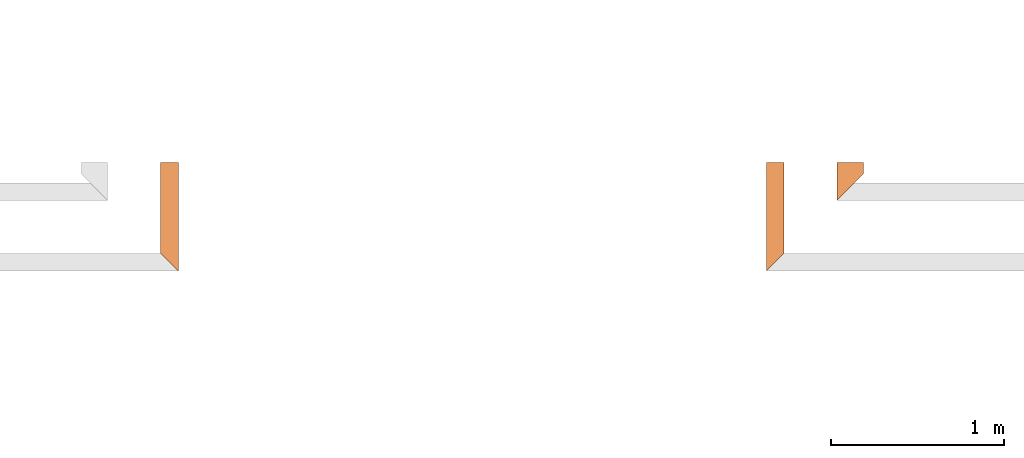
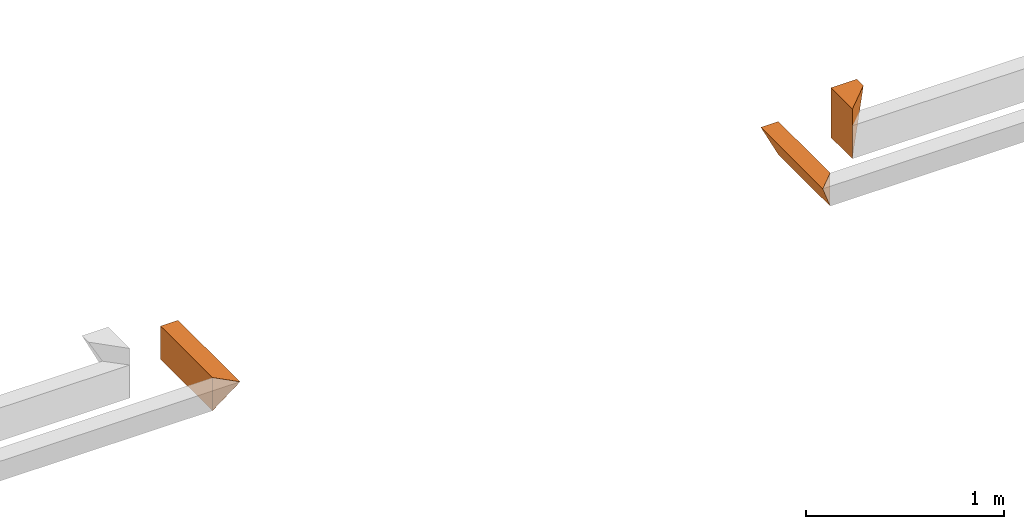
# One storey, part 8 of 8: 3 proxies.
"""IFC4 building model written with IfcOpenShell, lengths in feet."""

import ifcopenshell
import ifcopenshell.guid

model = None  # the IFC model being written
_history = None  # IfcOwnerHistory: only IFC2X3 demands one
_inside = {}  # id of a spatial element -> (the spatial element, [elements in it])
_under = {}  # id of a project, library or spatial element -> (it, [spatial elements below it])
_declared = {}  # id of a project -> (the project, [libraries it declares])
_typed = {}  # id of a type object -> (the type object, [elements of that type])
_made_of = {}  # id of a material, layer set ... -> (it, [elements and type objects made of it])


def new_model(schema):
    """Start an empty IFC model of exactly this schema.

    Asked for "IFC4X3", IfcOpenShell would pick the latest addendum, in which some entities
    have other attributes; the version numbers below select the first issue.
    IFC2X3 requires an IfcOwnerHistory on every rooted entity: one is made here for all.
    """
    global model, _history
    if schema == "IFC4X3":
        model = ifcopenshell.file(schema_version=(4, 3, 0, 0))
    else:
        model = ifcopenshell.file(schema=schema)
    _inside.clear()
    _under.clear()
    _declared.clear()
    _typed.clear()
    _made_of.clear()
    _history = None
    if model.schema == "IFC2X3":
        org = make("IfcOrganization", Name="unknown")
        user = make(
            "IfcPersonAndOrganization",
            ThePerson=make("IfcPerson", FamilyName="unknown"),
            TheOrganization=org,
        )
        app = make(
            "IfcApplication",
            ApplicationDeveloper=org,
            Version="unknown",
            ApplicationFullName="unknown",
            ApplicationIdentifier="unknown",
        )
        _history = make(
            "IfcOwnerHistory",
            OwningUser=user,
            OwningApplication=app,
            ChangeAction="ADDED",
            CreationDate=0,
        )
    return model


def make(cls, **values):
    """One entity of the class cls with the attributes given. An attribute that is None is left unset."""
    return model.create_entity(
        cls, **{name: value for name, value in values.items() if value is not None}
    )


def entity(cls, *values):
    """Any entity or typed value of the class cls, its attributes in the order of the schema. None: left unset."""
    e = model.create_entity(cls)
    for i, value in enumerate(values):
        if value is not None:
            e[i] = value
    return e


def rooted(cls, **values):
    """An entity with a GlobalId (a new one), such as an element, a storey or a relation."""
    return make(cls, GlobalId=ifcopenshell.guid.new(), OwnerHistory=_history, **values)


def si_unit(unit_type, name, prefix=None):
    """IfcSIUnit, for example si_unit("LENGTHUNIT", "METRE", prefix="MILLI")."""
    return make("IfcSIUnit", UnitType=unit_type, Prefix=prefix, Name=name)


def converted_unit(unit_type, name, factor, base, dimensions=None, offset=None):
    """IfcConversionBasedUnit, such as the inch: factor (a typed value) times the base unit."""
    return make(
        "IfcConversionBasedUnit"
        if offset is None
        else "IfcConversionBasedUnitWithOffset",
        ConversionOffset=offset,
        Dimensions=None
        if dimensions is None
        else entity("IfcDimensionalExponents", *dimensions),
        UnitType=unit_type,
        Name=name,
        ConversionFactor=make(
            "IfcMeasureWithUnit", ValueComponent=factor, UnitComponent=base
        ),
    )


def derived_unit(unit_type, elements):
    """IfcDerivedUnit: a product of units, each with its exponent."""
    return make(
        "IfcDerivedUnit",
        Elements=[
            make("IfcDerivedUnitElement", Unit=unit, Exponent=power)
            for unit, power in elements
        ],
        UnitType=unit_type,
    )


def assignment(units):
    """IfcUnitAssignment: the units of a project."""
    return None if units is None else make("IfcUnitAssignment", Units=units)


def point(xyz):
    """IfcCartesianPoint."""
    return None if xyz is None else make("IfcCartesianPoint", Coordinates=xyz)


def direction(xyz):
    """IfcDirection."""
    return None if xyz is None else make("IfcDirection", DirectionRatios=xyz)


def frame(location, z_axis=None, x_axis=None):
    """IfcAxis2Placement3D, a coordinate frame: its origin and axes. An axis left out is left unset."""
    return make(
        "IfcAxis2Placement3D",
        Location=point(location),
        Axis=direction(z_axis),
        RefDirection=direction(x_axis),
    )


def origin():
    """The frame at (0, 0, 0) with its axes left unset."""
    return frame((0.0, 0.0, 0.0))


def place(relative_to, where):
    """IfcLocalPlacement: puts the frame where relative to a parent placement (None: the world)."""
    return make(
        "IfcLocalPlacement", PlacementRelTo=relative_to, RelativePlacement=where
    )


def context(
    kind, dimensions, precision=None, world=None, true_north=None, identifier=None
):
    """IfcGeometricRepresentationContext, for example the 3D "Model" context."""
    return make(
        "IfcGeometricRepresentationContext",
        ContextIdentifier=identifier,
        ContextType=kind,
        CoordinateSpaceDimension=dimensions,
        Precision=precision,
        WorldCoordinateSystem=world,
        TrueNorth=true_north,
    )


def subcontext(parent, identifier, kind, view, scale=None):
    """IfcGeometricRepresentationSubContext, for example "Body" below "Model"."""
    return make(
        "IfcGeometricRepresentationSubContext",
        ContextIdentifier=identifier,
        ContextType=kind,
        ParentContext=parent,
        TargetScale=scale,
        TargetView=view,
    )


def project(units=None, contexts=None):
    """IfcProject with its units and contexts."""
    return rooted(
        "IfcProject",
        Name="project",
        RepresentationContexts=contexts,
        UnitsInContext=assignment(units),
    )


def spatial(cls, under=None, at=None, **own):
    """A site, building, storey or space (cls), placed at a placement, below another one or the project."""
    s = rooted(cls, ObjectPlacement=at, **own)
    if under is not None:
        _under.setdefault(under.id(), (under, []))[1].append(s)
    return s


def shape(context_of_items, identifier, shape_type, items):
    """IfcShapeRepresentation: the items that make up one representation, for example the "Body"."""
    return make(
        "IfcShapeRepresentation",
        ContextOfItems=context_of_items,
        RepresentationIdentifier=identifier,
        RepresentationType=shape_type,
        Items=items,
    )


def made_of(thing, what):
    """Note that an element or type object is made of a material, layer set ...; save() writes the relation."""
    if what is not None:
        _made_of.setdefault(what.id(), (what, []))[1].append(thing)
    return thing


def type_object(cls, material=None, **own):
    """A type object (cls), such as IfcWallType, which elements share."""
    return made_of(rooted(cls, **own), material)


def element(
    cls,
    number,
    at=None,
    inside=None,
    cuts=None,
    type_object=None,
    material=None,
    context=None,
    identifier="Body",
    shape_type=None,
    held_by="IfcProductDefinitionShape",
    body=None,
    shapes=None,
    **own,
):
    """One element of the class cls, such as IfcWall. Its Tag is "e" and its number.

    at: its placement. inside: the storey or other place that contains it. cuts: it is an
    opening in that element (IfcRelVoidsElement). A single representation is given by context,
    identifier, shape_type and body (its items); several are given by shapes. held_by: the class
    of the entity that holds the representations. save() writes the other relations.
    """
    e = rooted(cls, Tag="e%d" % number, ObjectPlacement=at, **own)
    if body is not None:
        shapes = [shape(context, identifier, shape_type, body)]
    if shapes is not None:
        e.Representation = make(held_by, Representations=shapes)
    if inside is not None:
        _inside.setdefault(inside.id(), (inside, []))[1].append(e)
    if cuts is not None:
        rooted(
            "IfcRelVoidsElement", RelatingBuildingElement=cuts, RelatedOpeningElement=e
        )
    if type_object is not None:
        _typed.setdefault(type_object.id(), (type_object, []))[1].append(e)
    return made_of(e, material)


def aggregate(whole, parts):
    """IfcRelAggregates: a whole, such as a stair, and the parts it consists of."""
    return rooted("IfcRelAggregates", RelatingObject=whole, RelatedObjects=parts)


def save(model, path):
    """Write the relations noted so far, then the file.

    IfcRelAggregates (storeys below a building ...), IfcRelContainedInSpatialStructure (elements
    in a storey), IfcRelDefinesByType, IfcRelAssociatesMaterial and IfcRelDeclares: one each for
    every whole, place, type object, material and project.
    """
    for whole, parts in _under.values():
        aggregate(whole, parts)
    for where, things in _inside.values():
        rooted(
            "IfcRelContainedInSpatialStructure",
            RelatedElements=things,
            RelatingStructure=where,
        )
    for kind, things in _typed.values():
        rooted("IfcRelDefinesByType", RelatedObjects=things, RelatingType=kind)
    for what, things in _made_of.values():
        rooted("IfcRelAssociatesMaterial", RelatedObjects=things, RelatingMaterial=what)
    for by, libraries in _declared.values():
        rooted("IfcRelDeclares", RelatingContext=by, RelatedDefinitions=libraries)
    model.write(path)


model = new_model("IFC4")

# Units and contexts
model_context = context("Model", 3, precision=0.0001, world=origin(), true_north=direction((6.12303176911189e-17, 1.0)))
body_context = subcontext(model_context, "Body", "Model", "MODEL_VIEW")
ifc_project = project(units=[converted_unit("LENGTHUNIT", "FOOT", entity("IfcRatioMeasure", 0.3048), si_unit("LENGTHUNIT", "METRE"), dimensions=[1, 0, 0, 0, 0, 0, 0]), converted_unit("AREAUNIT", "SQUARE FOOT", entity("IfcRatioMeasure", 0.09290304), si_unit("AREAUNIT", "SQUARE_METRE"), dimensions=[2, 0, 0, 0, 0, 0, 0]), converted_unit("VOLUMEUNIT", "CUBIC FOOT", entity("IfcRatioMeasure", 0.028316846592), si_unit("VOLUMEUNIT", "CUBIC_METRE"), dimensions=[3, 0, 0, 0, 0, 0, 0]), converted_unit("PLANEANGLEUNIT", "DEGREE", entity("IfcRatioMeasure", 0.0174532925199433), si_unit("PLANEANGLEUNIT", "RADIAN"), dimensions=[0, 0, 0, 0, 0, 0, 0]), si_unit("MASSUNIT", "GRAM", prefix="KILO"), derived_unit("MASSDENSITYUNIT", [(si_unit("MASSUNIT", "GRAM", prefix="KILO"), 1), (si_unit("LENGTHUNIT", "METRE"), -3)]), derived_unit("MOMENTOFINERTIAUNIT", [(si_unit("LENGTHUNIT", "METRE"), 4)]), si_unit("TIMEUNIT", "SECOND"), si_unit("FREQUENCYUNIT", "HERTZ"), si_unit("THERMODYNAMICTEMPERATUREUNIT", "DEGREE_CELSIUS"), derived_unit("THERMALTRANSMITTANCEUNIT", [(si_unit("MASSUNIT", "GRAM", prefix="KILO"), 1), (si_unit("THERMODYNAMICTEMPERATUREUNIT", "KELVIN"), -1), (si_unit("TIMEUNIT", "SECOND"), -3)]), derived_unit("VOLUMETRICFLOWRATEUNIT", [(si_unit("LENGTHUNIT", "METRE"), 3), (si_unit("TIMEUNIT", "SECOND"), -1)]), si_unit("ELECTRICCURRENTUNIT", "AMPERE"), si_unit("ELECTRICVOLTAGEUNIT", "VOLT"), si_unit("POWERUNIT", "WATT"), si_unit("FORCEUNIT", "NEWTON"), si_unit("ILLUMINANCEUNIT", "LUX"), si_unit("LUMINOUSFLUXUNIT", "LUMEN"), si_unit("LUMINOUSINTENSITYUNIT", "CANDELA"), derived_unit("USERDEFINED", [(si_unit("MASSUNIT", "GRAM", prefix="KILO"), -1), (si_unit("LENGTHUNIT", "METRE"), -2), (si_unit("TIMEUNIT", "SECOND"), 3), (si_unit("LUMINOUSFLUXUNIT", "LUMEN"), 1)]), derived_unit("LINEARVELOCITYUNIT", [(si_unit("LENGTHUNIT", "METRE"), 1), (si_unit("TIMEUNIT", "SECOND"), -1)]), si_unit("PRESSUREUNIT", "PASCAL"), derived_unit("USERDEFINED", [(si_unit("LENGTHUNIT", "METRE"), -2), (si_unit("MASSUNIT", "GRAM", prefix="KILO"), 1), (si_unit("TIMEUNIT", "SECOND"), -2)]), derived_unit("LINEARFORCEUNIT", [(si_unit("MASSUNIT", "GRAM", prefix="KILO"), 1), (si_unit("LENGTHUNIT", "METRE"), 1), (si_unit("TIMEUNIT", "SECOND"), -2), (si_unit("LENGTHUNIT", "METRE"), -1)]), derived_unit("PLANARFORCEUNIT", [(si_unit("MASSUNIT", "GRAM", prefix="KILO"), 1), (si_unit("LENGTHUNIT", "METRE"), 1), (si_unit("TIMEUNIT", "SECOND"), -2), (si_unit("LENGTHUNIT", "METRE"), -2)])], contexts=[model_context])

# Site, building, storey
site_placement = place(None, origin())
site = spatial("IfcSite", under=ifc_project, at=site_placement, CompositionType="ELEMENT")
building_placement = place(site_placement, origin())
building = spatial("IfcBuilding", under=site, at=building_placement, CompositionType="ELEMENT")
storey_placement = place(building_placement, frame((0.0, 0.0, -12.6666666666667)))
storey = spatial("IfcBuildingStorey", under=building, at=storey_placement, Name="BASEMENT", CompositionType="ELEMENT", Elevation=-12.6666666666667)

# Proxies
building_element_proxy_type_1 = type_object("IfcBuildingElementProxyType", PredefinedType="NOTDEFINED")
proxy_1_placement = place(storey_placement, frame((-171.238160287975, 955.897091132648, 11.5833333333333)))
cartesian_point_1 = entity("IfcCartesianPoint", [0.0, 2.04818742148973, 0.0])
vertex_point_1 = entity("IfcVertexPoint", cartesian_point_1)
cartesian_point_2 = entity("IfcCartesianPoint", [0.0, 2.04818742148973, 0.669270833333343])
vertex_point_2 = entity("IfcVertexPoint", cartesian_point_2)
ifc_direction_1 = entity("IfcDirection", [0.0, 0.0, 1.0])
edge_curve_1 = entity("IfcEdgeCurve", vertex_point_1, vertex_point_2, entity("IfcTrimmedCurve", entity("IfcLine", cartesian_point_1, entity("IfcVector", ifc_direction_1, 1.0)), [cartesian_point_1], [cartesian_point_2], True, "CARTESIAN"), True)
cartesian_point_3 = entity("IfcCartesianPoint", [0.334635416666799, 2.04818742148962, 0.669270833333343])
vertex_point_3 = entity("IfcVertexPoint", cartesian_point_3)
ifc_direction_2 = entity("IfcDirection", [1.0, 0.0, 0.0])
edge_curve_2 = entity("IfcEdgeCurve", vertex_point_2, vertex_point_3, entity("IfcTrimmedCurve", entity("IfcLine", cartesian_point_2, entity("IfcVector", ifc_direction_2, 1.0)), [cartesian_point_2], [cartesian_point_3], True, "CARTESIAN"), True)
edge_curve_3 = entity("IfcEdgeCurve", vertex_point_3, vertex_point_1, entity("IfcTrimmedCurve", entity("IfcLine", cartesian_point_3, entity("IfcVector", entity("IfcDirection", [-0.447213595499947, 0.0, -0.894427190999921]), 1.0)), [cartesian_point_3], [cartesian_point_1], True, "CARTESIAN"), True)
ifc_direction_3 = entity("IfcDirection", [0.0, 1.0, 0.0])
ifc_direction_4 = entity("IfcDirection", [0.0, 0.0, -1.0])
cartesian_point_4 = entity("IfcCartesianPoint", [0.0, 0.334635416666629, 0.0])
vertex_point_4 = entity("IfcVertexPoint", cartesian_point_4)
cartesian_point_5 = entity("IfcCartesianPoint", [0.334635416666742, 0.0, 0.669270833333343])
vertex_point_5 = entity("IfcVertexPoint", cartesian_point_5)
edge_curve_4 = entity("IfcEdgeCurve", vertex_point_4, vertex_point_5, entity("IfcTrimmedCurve", entity("IfcLine", cartesian_point_4, entity("IfcVector", entity("IfcDirection", [0.40824829046386, -0.408248290463825, 0.816496580927747]), 1.0)), [cartesian_point_4], [cartesian_point_5], True, "CARTESIAN"), True)
cartesian_point_6 = entity("IfcCartesianPoint", [0.0, 0.334635416666742, 0.669270833333343])
vertex_point_6 = entity("IfcVertexPoint", cartesian_point_6)
edge_curve_5 = entity("IfcEdgeCurve", vertex_point_5, vertex_point_6, entity("IfcTrimmedCurve", entity("IfcLine", cartesian_point_5, entity("IfcVector", entity("IfcDirection", [-0.707106781186517, 0.707106781186578, 0.0]), 1.0)), [cartesian_point_5], [cartesian_point_6], True, "CARTESIAN"), True)
edge_curve_6 = entity("IfcEdgeCurve", vertex_point_6, vertex_point_4, entity("IfcTrimmedCurve", entity("IfcLine", cartesian_point_6, entity("IfcVector", ifc_direction_4, 1.0)), [cartesian_point_6], [cartesian_point_4], True, "CARTESIAN"), True)
ifc_direction_5 = entity("IfcDirection", [0.0, -1.0, 0.0])
edge_curve_7 = entity("IfcEdgeCurve", vertex_point_1, vertex_point_4, entity("IfcTrimmedCurve", entity("IfcLine", cartesian_point_1, entity("IfcVector", ifc_direction_5, 1.0)), [cartesian_point_1], [cartesian_point_4], True, "CARTESIAN"), True)
edge_curve_8 = entity("IfcEdgeCurve", vertex_point_6, vertex_point_2, entity("IfcTrimmedCurve", entity("IfcLine", cartesian_point_6, entity("IfcVector", ifc_direction_3, 1.0)), [cartesian_point_6], [cartesian_point_2], True, "CARTESIAN"), True)
edge_curve_9 = entity("IfcEdgeCurve", vertex_point_3, vertex_point_5, entity("IfcTrimmedCurve", entity("IfcLine", cartesian_point_3, entity("IfcVector", ifc_direction_5, 1.0)), [cartesian_point_3], [cartesian_point_5], True, "CARTESIAN"), True)
element("IfcBuildingElementProxy", 1, at=proxy_1_placement, inside=storey, type_object=building_element_proxy_type_1, PredefinedType="NOTDEFINED", context=body_context, shape_type="AdvancedBrep", body=[
    entity("IfcAdvancedBrep", entity("IfcClosedShell", [entity("IfcAdvancedFace", [entity("IfcFaceOuterBound", entity("IfcEdgeLoop", [entity("IfcOrientedEdge", None, None, edge_curve_1, True), entity("IfcOrientedEdge", None, None, edge_curve_2, True), entity("IfcOrientedEdge", None, None, edge_curve_3, True)]), True)], entity("IfcPlane", entity("IfcAxis2Placement3D", entity("IfcCartesianPoint", [-1.0, 2.04818742148973, 1.0]), ifc_direction_3, ifc_direction_4)), True), entity("IfcAdvancedFace", [entity("IfcFaceOuterBound", entity("IfcEdgeLoop", [entity("IfcOrientedEdge", None, None, edge_curve_4, True), entity("IfcOrientedEdge", None, None, edge_curve_5, True), entity("IfcOrientedEdge", None, None, edge_curve_6, True)]), True)], entity("IfcPlane", entity("IfcAxis2Placement3D", entity("IfcCartesianPoint", [0.0, 0.334635416666629, 2.0]), entity("IfcDirection", [-0.707106781186562, -0.707106781186533, 0.0]), entity("IfcDirection", [-0.707106781186533, 0.707106781186562, 0.0]))), True), entity("IfcAdvancedFace", [entity("IfcFaceOuterBound", entity("IfcEdgeLoop", [entity("IfcOrientedEdge", None, None, edge_curve_7, True), entity("IfcOrientedEdge", None, None, edge_curve_6, False), entity("IfcOrientedEdge", None, None, edge_curve_8, True), entity("IfcOrientedEdge", None, None, edge_curve_1, False)]), True)], entity("IfcPlane", entity("IfcAxis2Placement3D", cartesian_point_1, entity("IfcDirection", [-1.0, 0.0, 0.0]), ifc_direction_5)), True), entity("IfcAdvancedFace", [entity("IfcFaceOuterBound", entity("IfcEdgeLoop", [entity("IfcOrientedEdge", None, None, edge_curve_7, False), entity("IfcOrientedEdge", None, None, edge_curve_3, False), entity("IfcOrientedEdge", None, None, edge_curve_9, True), entity("IfcOrientedEdge", None, None, edge_curve_4, False)]), True)], entity("IfcPlane", entity("IfcAxis2Placement3D", entity("IfcCartesianPoint", [0.500000000000142, 2.04818742148962, 1.0]), entity("IfcDirection", [0.894427190999915, 0.0, -0.447213595499961]), ifc_direction_5)), True), entity("IfcAdvancedFace", [entity("IfcFaceOuterBound", entity("IfcEdgeLoop", [entity("IfcOrientedEdge", None, None, edge_curve_2, False), entity("IfcOrientedEdge", None, None, edge_curve_8, False), entity("IfcOrientedEdge", None, None, edge_curve_5, False), entity("IfcOrientedEdge", None, None, edge_curve_9, False)]), True)], entity("IfcPlane", entity("IfcAxis2Placement3D", entity("IfcCartesianPoint", [29.5000074770008, 2.96484375000227, 0.669270833333343]), ifc_direction_1, ifc_direction_2)), True)])),
])
building_element_proxy_type_2 = type_object("IfcBuildingElementProxyType", PredefinedType="NOTDEFINED")
proxy_2_placement = place(storey_placement, frame((-158.446493847068, 957.231726549315, 11.5833333333333)))
cartesian_point_7 = entity("IfcCartesianPoint", [0.5, 0.713552004822759, 1.0])
vertex_point_7 = entity("IfcVertexPoint", cartesian_point_7)
cartesian_point_8 = entity("IfcCartesianPoint", [0.0, 0.713552004822759, 0.0])
vertex_point_8 = entity("IfcVertexPoint", cartesian_point_8)
edge_curve_10 = entity("IfcEdgeCurve", vertex_point_7, vertex_point_8, entity("IfcTrimmedCurve", entity("IfcLine", cartesian_point_7, entity("IfcVector", entity("IfcDirection", [-0.44721359549996, 0.0, -0.894427190999915]), 1.0)), [cartesian_point_7], [cartesian_point_8], True, "CARTESIAN"), True)
cartesian_point_9 = entity("IfcCartesianPoint", [0.0, 0.713552004822759, 0.669270833333341])
vertex_point_9 = entity("IfcVertexPoint", cartesian_point_9)
ifc_direction_6 = entity("IfcDirection", [0.0, 0.0, 1.0])
edge_curve_11 = entity("IfcEdgeCurve", vertex_point_8, vertex_point_9, entity("IfcTrimmedCurve", entity("IfcLine", cartesian_point_8, entity("IfcVector", ifc_direction_6, 1.0)), [cartesian_point_8], [cartesian_point_9], True, "CARTESIAN"), True)
cartesian_point_10 = entity("IfcCartesianPoint", [0.0, 0.713552004822759, 1.0])
vertex_point_10 = entity("IfcVertexPoint", cartesian_point_10)
edge_curve_12 = entity("IfcEdgeCurve", vertex_point_9, vertex_point_10, entity("IfcTrimmedCurve", entity("IfcLine", cartesian_point_9, entity("IfcVector", ifc_direction_6, 1.0)), [cartesian_point_9], [cartesian_point_10], True, "CARTESIAN"), True)
edge_curve_13 = entity("IfcEdgeCurve", vertex_point_10, vertex_point_7, entity("IfcTrimmedCurve", entity("IfcLine", cartesian_point_10, entity("IfcVector", entity("IfcDirection", [1.0, 0.0, 0.0]), 1.0)), [cartesian_point_10], [cartesian_point_7], True, "CARTESIAN"), True)
ifc_direction_7 = entity("IfcDirection", [0.0, 1.0, 0.0])
ifc_direction_8 = entity("IfcDirection", [0.0, 0.0, -1.0])
cartesian_point_11 = entity("IfcCartesianPoint", [0.0, 0.0, 0.0])
vertex_point_11 = entity("IfcVertexPoint", cartesian_point_11)
cartesian_point_12 = entity("IfcCartesianPoint", [0.500000000000028, 0.499999999999886, 1.0])
vertex_point_12 = entity("IfcVertexPoint", cartesian_point_12)
edge_curve_14 = entity("IfcEdgeCurve", vertex_point_11, vertex_point_12, entity("IfcTrimmedCurve", entity("IfcLine", cartesian_point_11, entity("IfcVector", entity("IfcDirection", [0.408248290463864, 0.408248290463864, 0.816496580927725]), 1.0)), [cartesian_point_11], [cartesian_point_12], True, "CARTESIAN"), True)
cartesian_point_13 = entity("IfcCartesianPoint", [0.0, 0.0, 1.0])
vertex_point_13 = entity("IfcVertexPoint", cartesian_point_13)
edge_curve_15 = entity("IfcEdgeCurve", vertex_point_12, vertex_point_13, entity("IfcTrimmedCurve", entity("IfcLine", cartesian_point_12, entity("IfcVector", entity("IfcDirection", [-0.707106781186547, -0.707106781186547, 0.0]), 1.0)), [cartesian_point_12], [cartesian_point_13], True, "CARTESIAN"), True)
cartesian_point_14 = entity("IfcCartesianPoint", [0.0, 0.0, 0.669270833333341])
vertex_point_14 = entity("IfcVertexPoint", cartesian_point_14)
edge_curve_16 = entity("IfcEdgeCurve", vertex_point_13, vertex_point_14, entity("IfcTrimmedCurve", entity("IfcLine", cartesian_point_13, entity("IfcVector", ifc_direction_8, 1.0)), [cartesian_point_13], [cartesian_point_14], True, "CARTESIAN"), True)
edge_curve_17 = entity("IfcEdgeCurve", vertex_point_14, vertex_point_11, entity("IfcTrimmedCurve", entity("IfcLine", cartesian_point_14, entity("IfcVector", ifc_direction_8, 1.0)), [cartesian_point_14], [cartesian_point_11], True, "CARTESIAN"), True)
ifc_direction_9 = entity("IfcDirection", [0.0, -1.0, 0.0])
edge_curve_18 = entity("IfcEdgeCurve", vertex_point_7, vertex_point_12, entity("IfcTrimmedCurve", entity("IfcLine", cartesian_point_7, entity("IfcVector", ifc_direction_9, 1.0)), [cartesian_point_7], [cartesian_point_12], True, "CARTESIAN"), True)
edge_curve_19 = entity("IfcEdgeCurve", vertex_point_11, vertex_point_8, entity("IfcTrimmedCurve", entity("IfcLine", cartesian_point_8, entity("IfcVector", ifc_direction_7, 1.0)), [cartesian_point_11], [cartesian_point_8], True, "CARTESIAN"), True)
edge_curve_20 = entity("IfcEdgeCurve", vertex_point_10, vertex_point_13, entity("IfcTrimmedCurve", entity("IfcLine", cartesian_point_10, entity("IfcVector", ifc_direction_9, 1.0)), [cartesian_point_10], [cartesian_point_13], True, "CARTESIAN"), True)
element("IfcBuildingElementProxy", 2, at=proxy_2_placement, inside=storey, type_object=building_element_proxy_type_2, PredefinedType="NOTDEFINED", context=body_context, shape_type="AdvancedBrep", body=[
    entity("IfcAdvancedBrep", entity("IfcClosedShell", [entity("IfcAdvancedFace", [entity("IfcFaceOuterBound", entity("IfcEdgeLoop", [entity("IfcOrientedEdge", None, None, edge_curve_10, True), entity("IfcOrientedEdge", None, None, edge_curve_11, True), entity("IfcOrientedEdge", None, None, edge_curve_12, True), entity("IfcOrientedEdge", None, None, edge_curve_13, True)]), True)], entity("IfcPlane", entity("IfcAxis2Placement3D", entity("IfcCartesianPoint", [-1.0, 0.713552004822645, 1.0]), ifc_direction_7, ifc_direction_8)), True), entity("IfcAdvancedFace", [entity("IfcFaceOuterBound", entity("IfcEdgeLoop", [entity("IfcOrientedEdge", None, None, edge_curve_14, True), entity("IfcOrientedEdge", None, None, edge_curve_15, True), entity("IfcOrientedEdge", None, None, edge_curve_16, True), entity("IfcOrientedEdge", None, None, edge_curve_17, True)]), True)], entity("IfcPlane", entity("IfcAxis2Placement3D", cartesian_point_11, entity("IfcDirection", [0.707106781186548, -0.707106781186548, 0.0]), entity("IfcDirection", [0.707106781186548, 0.707106781186548, 0.0]))), True), entity("IfcAdvancedFace", [entity("IfcFaceOuterBound", entity("IfcEdgeLoop", [entity("IfcOrientedEdge", None, None, edge_curve_10, False), entity("IfcOrientedEdge", None, None, edge_curve_18, True), entity("IfcOrientedEdge", None, None, edge_curve_14, False), entity("IfcOrientedEdge", None, None, edge_curve_19, True)]), True)], entity("IfcPlane", entity("IfcAxis2Placement3D", cartesian_point_7, entity("IfcDirection", [0.894427190999915, 0.0, -0.447213595499961]), ifc_direction_9)), True), entity("IfcAdvancedFace", [entity("IfcFaceOuterBound", entity("IfcEdgeLoop", [entity("IfcOrientedEdge", None, None, edge_curve_13, False), entity("IfcOrientedEdge", None, None, edge_curve_20, True), entity("IfcOrientedEdge", None, None, edge_curve_15, False), entity("IfcOrientedEdge", None, None, edge_curve_18, False)]), True)], entity("IfcPlane", entity("IfcAxis2Placement3D", cartesian_point_10, ifc_direction_6, ifc_direction_9)), True), entity("IfcAdvancedFace", [entity("IfcFaceOuterBound", entity("IfcEdgeLoop", [entity("IfcOrientedEdge", None, None, edge_curve_20, False), entity("IfcOrientedEdge", None, None, edge_curve_12, False), entity("IfcOrientedEdge", None, None, edge_curve_11, False), entity("IfcOrientedEdge", None, None, edge_curve_19, False), entity("IfcOrientedEdge", None, None, edge_curve_17, False), entity("IfcOrientedEdge", None, None, edge_curve_16, False)]), True)], entity("IfcPlane", entity("IfcAxis2Placement3D", cartesian_point_8, entity("IfcDirection", [-1.0, 0.0, 0.0]), ifc_direction_9)), True)])),
])
building_element_proxy_type_3 = type_object("IfcBuildingElementProxyType", PredefinedType="NOTDEFINED")
proxy_3_placement = place(storey_placement, frame((-159.781129263735, 955.897091132648, 11.5833333333333)))
cartesian_point_15 = entity("IfcCartesianPoint", [0.334635416666686, 2.0481874214895, 0.0])
vertex_point_15 = entity("IfcVertexPoint", cartesian_point_15)
cartesian_point_16 = entity("IfcCartesianPoint", [0.0, 2.04818742148939, 0.669270833333343])
vertex_point_16 = entity("IfcVertexPoint", cartesian_point_16)
edge_curve_21 = entity("IfcEdgeCurve", vertex_point_15, vertex_point_16, entity("IfcTrimmedCurve", entity("IfcLine", cartesian_point_15, entity("IfcVector", entity("IfcDirection", [-0.447213595499947, 0.0, 0.894427190999921]), 1.0)), [cartesian_point_15], [cartesian_point_16], True, "CARTESIAN"), True)
cartesian_point_17 = entity("IfcCartesianPoint", [0.334635416666686, 2.0481874214895, 0.669270833333343])
vertex_point_17 = entity("IfcVertexPoint", cartesian_point_17)
ifc_direction_10 = entity("IfcDirection", [1.0, 0.0, 0.0])
edge_curve_22 = entity("IfcEdgeCurve", vertex_point_16, vertex_point_17, entity("IfcTrimmedCurve", entity("IfcLine", cartesian_point_16, entity("IfcVector", ifc_direction_10, 1.0)), [cartesian_point_16], [cartesian_point_17], True, "CARTESIAN"), True)
ifc_direction_11 = entity("IfcDirection", [0.0, 0.0, -1.0])
edge_curve_23 = entity("IfcEdgeCurve", vertex_point_17, vertex_point_15, entity("IfcTrimmedCurve", entity("IfcLine", cartesian_point_17, entity("IfcVector", ifc_direction_11, 1.0)), [cartesian_point_17], [cartesian_point_15], True, "CARTESIAN"), True)
ifc_direction_12 = entity("IfcDirection", [0.0, 1.0, 0.0])
cartesian_point_18 = entity("IfcCartesianPoint", [0.334635416666742, 0.334635416666629, 0.0])
vertex_point_18 = entity("IfcVertexPoint", cartesian_point_18)
cartesian_point_19 = entity("IfcCartesianPoint", [0.334635416666742, 0.334635416666629, 0.669270833333343])
vertex_point_19 = entity("IfcVertexPoint", cartesian_point_19)
ifc_direction_13 = entity("IfcDirection", [0.0, 0.0, 1.0])
edge_curve_24 = entity("IfcEdgeCurve", vertex_point_18, vertex_point_19, entity("IfcTrimmedCurve", entity("IfcLine", cartesian_point_18, entity("IfcVector", ifc_direction_13, 1.0)), [cartesian_point_18], [cartesian_point_19], True, "CARTESIAN"), True)
cartesian_point_20 = entity("IfcCartesianPoint", [0.0, 0.0, 0.669270833333343])
vertex_point_20 = entity("IfcVertexPoint", cartesian_point_20)
edge_curve_25 = entity("IfcEdgeCurve", vertex_point_19, vertex_point_20, entity("IfcTrimmedCurve", entity("IfcLine", cartesian_point_19, entity("IfcVector", entity("IfcDirection", [-0.707106781186578, -0.707106781186517, 0.0]), 1.0)), [cartesian_point_19], [cartesian_point_20], True, "CARTESIAN"), True)
edge_curve_26 = entity("IfcEdgeCurve", vertex_point_20, vertex_point_18, entity("IfcTrimmedCurve", entity("IfcLine", cartesian_point_20, entity("IfcVector", entity("IfcDirection", [0.40824829046386, 0.408248290463825, -0.816496580927747]), 1.0)), [cartesian_point_20], [cartesian_point_18], True, "CARTESIAN"), True)
edge_curve_27 = entity("IfcEdgeCurve", vertex_point_18, vertex_point_15, entity("IfcTrimmedCurve", entity("IfcLine", cartesian_point_15, entity("IfcVector", ifc_direction_12, 1.0)), [cartesian_point_18], [cartesian_point_15], True, "CARTESIAN"), True)
ifc_direction_14 = entity("IfcDirection", [0.0, -1.0, 0.0])
edge_curve_28 = entity("IfcEdgeCurve", vertex_point_17, vertex_point_19, entity("IfcTrimmedCurve", entity("IfcLine", cartesian_point_17, entity("IfcVector", ifc_direction_14, 1.0)), [cartesian_point_17], [cartesian_point_19], True, "CARTESIAN"), True)
edge_curve_29 = entity("IfcEdgeCurve", vertex_point_20, vertex_point_16, entity("IfcTrimmedCurve", entity("IfcLine", cartesian_point_20, entity("IfcVector", ifc_direction_12, 1.0)), [cartesian_point_20], [cartesian_point_16], True, "CARTESIAN"), True)
element("IfcBuildingElementProxy", 3, at=proxy_3_placement, inside=storey, type_object=building_element_proxy_type_3, PredefinedType="NOTDEFINED", context=body_context, shape_type="AdvancedBrep", body=[
    entity("IfcAdvancedBrep", entity("IfcClosedShell", [entity("IfcAdvancedFace", [entity("IfcFaceOuterBound", entity("IfcEdgeLoop", [entity("IfcOrientedEdge", None, None, edge_curve_21, True), entity("IfcOrientedEdge", None, None, edge_curve_22, True), entity("IfcOrientedEdge", None, None, edge_curve_23, True)]), True)], entity("IfcPlane", entity("IfcAxis2Placement3D", entity("IfcCartesianPoint", [-0.665364583333314, 2.04818742148939, 1.0]), ifc_direction_12, ifc_direction_11)), True), entity("IfcAdvancedFace", [entity("IfcFaceOuterBound", entity("IfcEdgeLoop", [entity("IfcOrientedEdge", None, None, edge_curve_24, True), entity("IfcOrientedEdge", None, None, edge_curve_25, True), entity("IfcOrientedEdge", None, None, edge_curve_26, True)]), True)], entity("IfcPlane", entity("IfcAxis2Placement3D", cartesian_point_18, entity("IfcDirection", [0.707106781186548, -0.707106781186548, 0.0]), entity("IfcDirection", [0.707106781186548, 0.707106781186548, 0.0]))), True), entity("IfcAdvancedFace", [entity("IfcFaceOuterBound", entity("IfcEdgeLoop", [entity("IfcOrientedEdge", None, None, edge_curve_27, True), entity("IfcOrientedEdge", None, None, edge_curve_23, False), entity("IfcOrientedEdge", None, None, edge_curve_28, True), entity("IfcOrientedEdge", None, None, edge_curve_24, False)]), True)], entity("IfcPlane", entity("IfcAxis2Placement3D", entity("IfcCartesianPoint", [0.334635416666686, 2.0481874214895, 1.0]), ifc_direction_10, ifc_direction_14)), True), entity("IfcAdvancedFace", [entity("IfcFaceOuterBound", entity("IfcEdgeLoop", [entity("IfcOrientedEdge", None, None, edge_curve_27, False), entity("IfcOrientedEdge", None, None, edge_curve_26, False), entity("IfcOrientedEdge", None, None, edge_curve_29, True), entity("IfcOrientedEdge", None, None, edge_curve_21, False)]), True)], entity("IfcPlane", entity("IfcAxis2Placement3D", cartesian_point_15, entity("IfcDirection", [-0.894427190999915, 0.0, -0.447213595499961]), ifc_direction_14)), True), entity("IfcAdvancedFace", [entity("IfcFaceOuterBound", entity("IfcEdgeLoop", [entity("IfcOrientedEdge", None, None, edge_curve_22, False), entity("IfcOrientedEdge", None, None, edge_curve_29, False), entity("IfcOrientedEdge", None, None, edge_curve_25, False), entity("IfcOrientedEdge", None, None, edge_curve_28, False)]), True)], entity("IfcPlane", entity("IfcAxis2Placement3D", entity("IfcCartesianPoint", [18.0429764527609, 2.96484375000227, 0.669270833333343]), ifc_direction_13, ifc_direction_10)), True)])),
])

save(model, "model.ifc")
